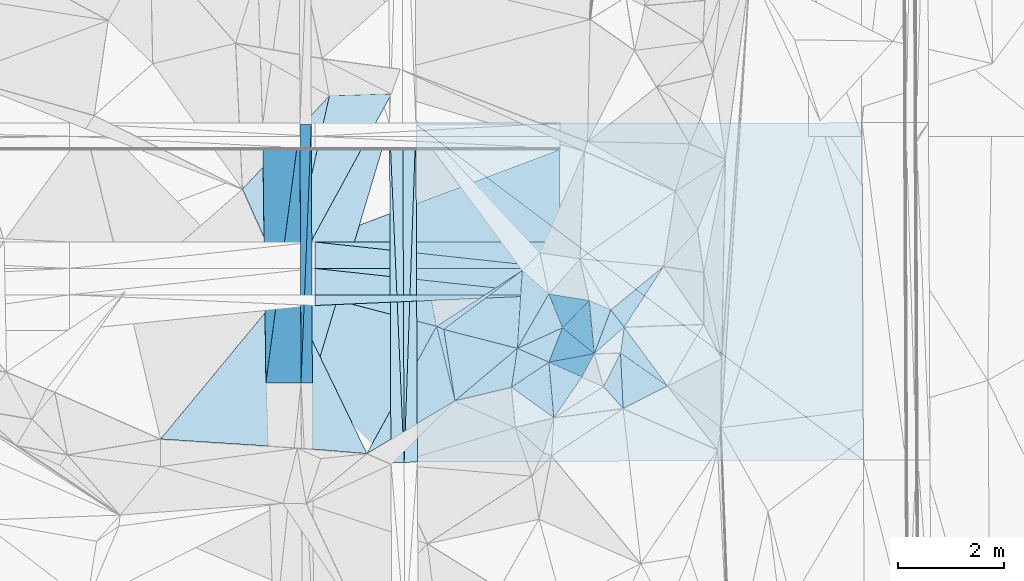
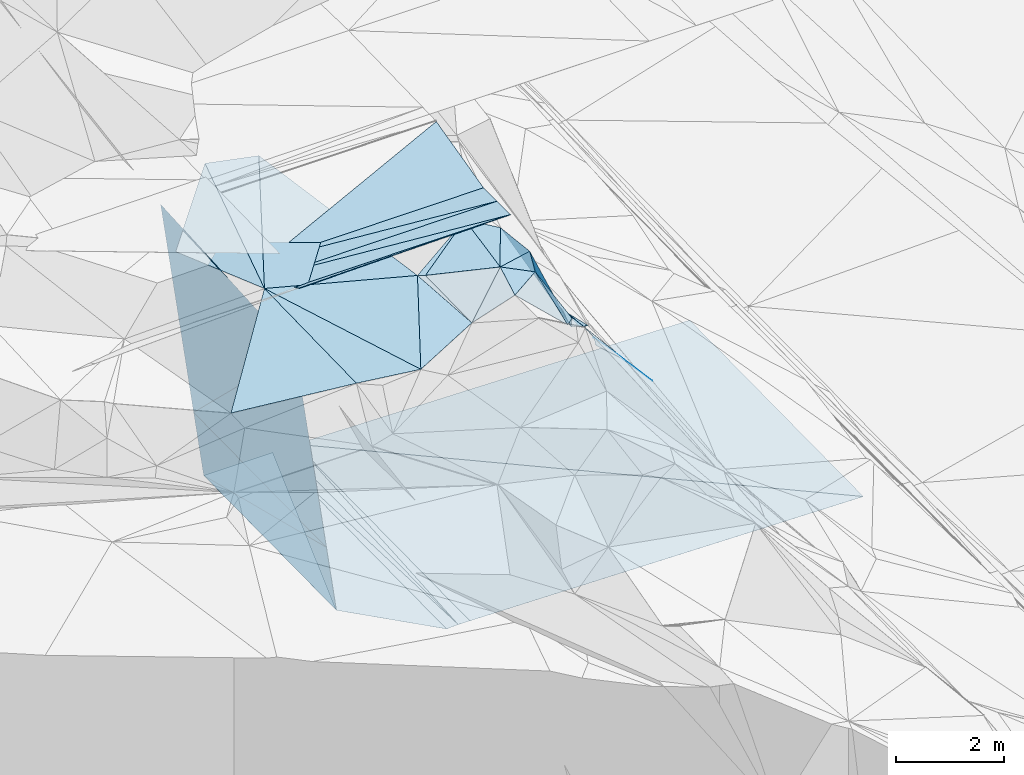
# One storey, part 59 of 275: 46 plates.
"""IFC2X3 building model written with IfcOpenShell, lengths in millimetres."""

import ifcopenshell
import ifcopenshell.guid

model = None  # the IFC model being written
_history = None  # IfcOwnerHistory: only IFC2X3 demands one
_inside = {}  # id of a spatial element -> (the spatial element, [elements in it])
_under = {}  # id of a project, library or spatial element -> (it, [spatial elements below it])
_declared = {}  # id of a project -> (the project, [libraries it declares])
_typed = {}  # id of a type object -> (the type object, [elements of that type])
_made_of = {}  # id of a material, layer set ... -> (it, [elements and type objects made of it])


def new_model(schema):
    """Start an empty IFC model of exactly this schema.

    Asked for "IFC4X3", IfcOpenShell would pick the latest addendum, in which some entities
    have other attributes; the version numbers below select the first issue.
    IFC2X3 requires an IfcOwnerHistory on every rooted entity: one is made here for all.
    """
    global model, _history
    if schema == "IFC4X3":
        model = ifcopenshell.file(schema_version=(4, 3, 0, 0))
    else:
        model = ifcopenshell.file(schema=schema)
    _inside.clear()
    _under.clear()
    _declared.clear()
    _typed.clear()
    _made_of.clear()
    _history = None
    if model.schema == "IFC2X3":
        org = make("IfcOrganization", Name="unknown")
        user = make(
            "IfcPersonAndOrganization",
            ThePerson=make("IfcPerson", FamilyName="unknown"),
            TheOrganization=org,
        )
        app = make(
            "IfcApplication",
            ApplicationDeveloper=org,
            Version="unknown",
            ApplicationFullName="unknown",
            ApplicationIdentifier="unknown",
        )
        _history = make(
            "IfcOwnerHistory",
            OwningUser=user,
            OwningApplication=app,
            ChangeAction="ADDED",
            CreationDate=0,
        )
    return model


def make(cls, **values):
    """One entity of the class cls with the attributes given. An attribute that is None is left unset."""
    return model.create_entity(
        cls, **{name: value for name, value in values.items() if value is not None}
    )


def rooted(cls, **values):
    """An entity with a GlobalId (a new one), such as an element, a storey or a relation."""
    return make(cls, GlobalId=ifcopenshell.guid.new(), OwnerHistory=_history, **values)


def si_unit(unit_type, name, prefix=None):
    """IfcSIUnit, for example si_unit("LENGTHUNIT", "METRE", prefix="MILLI")."""
    return make("IfcSIUnit", UnitType=unit_type, Prefix=prefix, Name=name)


def assignment(units):
    """IfcUnitAssignment: the units of a project."""
    return None if units is None else make("IfcUnitAssignment", Units=units)


def point(xyz):
    """IfcCartesianPoint."""
    return None if xyz is None else make("IfcCartesianPoint", Coordinates=xyz)


def direction(xyz):
    """IfcDirection."""
    return None if xyz is None else make("IfcDirection", DirectionRatios=xyz)


def frame(location, z_axis=None, x_axis=None):
    """IfcAxis2Placement3D, a coordinate frame: its origin and axes. An axis left out is left unset."""
    return make(
        "IfcAxis2Placement3D",
        Location=point(location),
        Axis=direction(z_axis),
        RefDirection=direction(x_axis),
    )


def origin_with_axes():
    """The frame at (0, 0, 0) with the z axis (0, 0, 1) and the x axis (1, 0, 0) written out."""
    return frame((0.0, 0.0, 0.0), z_axis=(0.0, 0.0, 1.0), x_axis=(1.0, 0.0, 0.0))


def place(relative_to, where):
    """IfcLocalPlacement: puts the frame where relative to a parent placement (None: the world)."""
    return make(
        "IfcLocalPlacement", PlacementRelTo=relative_to, RelativePlacement=where
    )


def context(
    kind, dimensions, precision=None, world=None, true_north=None, identifier=None
):
    """IfcGeometricRepresentationContext, for example the 3D "Model" context."""
    return make(
        "IfcGeometricRepresentationContext",
        ContextIdentifier=identifier,
        ContextType=kind,
        CoordinateSpaceDimension=dimensions,
        Precision=precision,
        WorldCoordinateSystem=world,
        TrueNorth=true_north,
    )


def subcontext(parent, identifier, kind, view, scale=None):
    """IfcGeometricRepresentationSubContext, for example "Body" below "Model"."""
    return make(
        "IfcGeometricRepresentationSubContext",
        ContextIdentifier=identifier,
        ContextType=kind,
        ParentContext=parent,
        TargetScale=scale,
        TargetView=view,
    )


def project(units=None, contexts=None):
    """IfcProject with its units and contexts."""
    return rooted(
        "IfcProject",
        Name="project",
        RepresentationContexts=contexts,
        UnitsInContext=assignment(units),
    )


def spatial(cls, under=None, at=None, **own):
    """A site, building, storey or space (cls), placed at a placement, below another one or the project."""
    s = rooted(cls, ObjectPlacement=at, **own)
    if under is not None:
        _under.setdefault(under.id(), (under, []))[1].append(s)
    return s


def polyline(points):
    """IfcPolyline through the points."""
    return make("IfcPolyline", Points=[point(p) for p in points])


def outline(outer, holes=None, kind="AREA"):
    """IfcArbitraryClosedProfileDef: a profile drawn as a closed curve; with holes, ...WithVoids."""
    if holes is None:
        return make("IfcArbitraryClosedProfileDef", ProfileType=kind, OuterCurve=outer)
    return make(
        "IfcArbitraryProfileDefWithVoids",
        ProfileType=kind,
        OuterCurve=outer,
        InnerCurves=holes,
    )


def extrude(swept, where, along, depth):
    """IfcExtrudedAreaSolid: the profile swept, set in the frame where, extruded along a direction by depth."""
    return make(
        "IfcExtrudedAreaSolid",
        SweptArea=swept,
        Position=where,
        ExtrudedDirection=direction(along),
        Depth=depth,
    )


def shape(context_of_items, identifier, shape_type, items):
    """IfcShapeRepresentation: the items that make up one representation, for example the "Body"."""
    return make(
        "IfcShapeRepresentation",
        ContextOfItems=context_of_items,
        RepresentationIdentifier=identifier,
        RepresentationType=shape_type,
        Items=items,
    )


def material(Name=None, Category=None):
    """IfcMaterial."""
    return make("IfcMaterial", Name=Name, Category=Category)


def made_of(thing, what):
    """Note that an element or type object is made of a material, layer set ...; save() writes the relation."""
    if what is not None:
        _made_of.setdefault(what.id(), (what, []))[1].append(thing)
    return thing


def type_object(cls, material=None, **own):
    """A type object (cls), such as IfcWallType, which elements share."""
    return made_of(rooted(cls, **own), material)


def element(
    cls,
    number,
    at=None,
    inside=None,
    cuts=None,
    type_object=None,
    material=None,
    context=None,
    identifier="Body",
    shape_type=None,
    held_by="IfcProductDefinitionShape",
    body=None,
    shapes=None,
    **own,
):
    """One element of the class cls, such as IfcWall. Its Tag is "e" and its number.

    at: its placement. inside: the storey or other place that contains it. cuts: it is an
    opening in that element (IfcRelVoidsElement). A single representation is given by context,
    identifier, shape_type and body (its items); several are given by shapes. held_by: the class
    of the entity that holds the representations. save() writes the other relations.
    """
    e = rooted(cls, Tag="e%d" % number, ObjectPlacement=at, **own)
    if body is not None:
        shapes = [shape(context, identifier, shape_type, body)]
    if shapes is not None:
        e.Representation = make(held_by, Representations=shapes)
    if inside is not None:
        _inside.setdefault(inside.id(), (inside, []))[1].append(e)
    if cuts is not None:
        rooted(
            "IfcRelVoidsElement", RelatingBuildingElement=cuts, RelatedOpeningElement=e
        )
    if type_object is not None:
        _typed.setdefault(type_object.id(), (type_object, []))[1].append(e)
    return made_of(e, material)


def aggregate(whole, parts):
    """IfcRelAggregates: a whole, such as a stair, and the parts it consists of."""
    return rooted("IfcRelAggregates", RelatingObject=whole, RelatedObjects=parts)


def save(model, path):
    """Write the relations noted so far, then the file.

    IfcRelAggregates (storeys below a building ...), IfcRelContainedInSpatialStructure (elements
    in a storey), IfcRelDefinesByType, IfcRelAssociatesMaterial and IfcRelDeclares: one each for
    every whole, place, type object, material and project.
    """
    for whole, parts in _under.values():
        aggregate(whole, parts)
    for where, things in _inside.values():
        rooted(
            "IfcRelContainedInSpatialStructure",
            RelatedElements=things,
            RelatingStructure=where,
        )
    for kind, things in _typed.values():
        rooted("IfcRelDefinesByType", RelatedObjects=things, RelatingType=kind)
    for what, things in _made_of.values():
        rooted("IfcRelAssociatesMaterial", RelatedObjects=things, RelatingMaterial=what)
    for by, libraries in _declared.values():
        rooted("IfcRelDeclares", RelatingContext=by, RelatedDefinitions=libraries)
    model.write(path)


model = new_model("IFC2X3")

# Units and contexts
model_context = context("Model", 3, precision=1e-05, world=origin_with_axes())
body_context = subcontext(model_context, "Body", "Model", "MODEL_VIEW")
ifc_project = project(units=[si_unit("LENGTHUNIT", "METRE", prefix="MILLI"), si_unit("AREAUNIT", "SQUARE_METRE"), si_unit("VOLUMEUNIT", "CUBIC_METRE"), si_unit("MASSUNIT", "GRAM", prefix="KILO"), si_unit("TIMEUNIT", "SECOND"), si_unit("PLANEANGLEUNIT", "RADIAN"), si_unit("SOLIDANGLEUNIT", "STERADIAN"), si_unit("THERMODYNAMICTEMPERATUREUNIT", "DEGREE_CELSIUS"), si_unit("LUMINOUSINTENSITYUNIT", "LUMEN")], contexts=[model_context])

# Site, building, storey
site_placement = place(None, origin_with_axes())
site = spatial("IfcSite", under=ifc_project, at=site_placement, CompositionType="ELEMENT")
building_placement = place(site_placement, origin_with_axes())
building = spatial("IfcBuilding", under=site, at=building_placement, Name="Undefined", CompositionType="ELEMENT")
storey_placement = place(building_placement, origin_with_axes())
storey = spatial("IfcBuildingStorey", under=building, at=storey_placement, Name="Undefined", CompositionType="ELEMENT", Elevation=0.0)

# Plates
ifc_material = material()
plate_type_1 = type_object("IfcPlateType", PredefinedType="NOTDEFINED")
plate_1_placement = place(storey_placement, frame((-105730.120090106, 55627.1401213638, 43859.1212907865), z_axis=(-0.989948726527029, -0.00130441056446912, -0.141420710508017), x_axis=(0.0381706499205315, 0.960384070101301, -0.276053327058928)))
element("IfcPlate", 1, at=plate_1_placement, inside=storey, type_object=plate_type_1, material=ifc_material, Name="00_PR", context=body_context, shape_type="SweptSolid", body=[
    extrude(outline(polyline([(0.0, 0.0), (5087.47705078125, 1.11322151497006e-08), (423.188995361328, 1454.93286132813), (0.0, 0.0)])), frame((-8.85201319254618e-08, 2.18876761149539e-07, -0.5000001331573), z_axis=(0.0, 0.0, 1.0), x_axis=(1.0, 0.0, 0.0)), (0.0, 0.0, 1.0), 1.0),
])
plate_2_placement = place(storey_placement, frame((-105535.927784358, 60513.072147531, 42454.7062909264), z_axis=(-0.989948726527029, -0.00130441056446912, -0.141420710508017), x_axis=(-0.038170649897134, -0.960384070108515, 0.276053327037065)))
element("IfcPlate", 2, at=plate_2_placement, inside=storey, type_object=plate_type_1, material=ifc_material, Name="00_PR", context=body_context, shape_type="SweptSolid", body=[
    extrude(outline(polyline([(0.0, 0.0), (5087.47705078125, 1.11322151497006e-08), (423.022155761719, 1454.98132324219), (0.0, 0.0)])), frame((-8.85201319254618e-08, 2.18876761149539e-07, -0.5000001331573), z_axis=(0.0, 0.0, 1.0), x_axis=(1.0, 0.0, 0.0)), (0.0, 0.0, 1.0), 1.0),
])
plate_type_2 = type_object("IfcPlateType", PredefinedType="NOTDEFINED")
plate_3_placement = place(storey_placement, frame((-104055.417053017, 60518.5701489042, 42454.277721949), z_axis=(0.0498544569168996, 0.019904250008953, -0.998558137494809), x_axis=(0.99874546627616, 0.00370463310154305, 0.0499376539937489)))
element("IfcPlate", 3, at=plate_3_placement, inside=storey, type_object=plate_type_2, material=ifc_material, Name="00_PR", context=body_context, shape_type="SweptSolid", body=[
    extrude(outline(polyline([(0.0, 0.0), (250.312118530273, 2.47382558882236e-10), (247.391189575195, 6396.5869140625), (0.0, 0.0)])), frame((-8.85201319254618e-08, 2.18876761149539e-07, -0.5000001331573), z_axis=(0.0, 0.0, 1.0), x_axis=(1.0, 0.0, 0.0)), (0.0, 0.0, 1.0), 1.0),
])
plate_4_placement = place(storey_placement, frame((-104055.417053017, 60518.5701489042, 42454.277721949), z_axis=(0.0498336597395354, 0.0199033673627597, -0.998559193200177), x_axis=(0.0432878790992274, -0.99890494977846, -0.0177499529910086)))
element("IfcPlate", 4, at=plate_4_placement, inside=storey, type_object=plate_type_2, material=ifc_material, Name="00_PR", context=body_context, shape_type="SweptSolid", body=[
    extrude(outline(polyline([(0.0, 0.0), (6401.369140625, -2.4156179279089e-09), (6391.95947265625, 250.135406494141), (0.0, 0.0)])), frame((-8.85201319254618e-08, 2.18876761149539e-07, -0.5000001331573), z_axis=(0.0, 0.0, 1.0), x_axis=(1.0, 0.0, 0.0)), (0.0, 0.0, 1.0), 1.0),
])
plate_5_placement = place(storey_placement, frame((-103778.350339783, 54124.2108116673, 42340.6531984239), z_axis=(-0.0200859532450271, 0.0196293112227441, -0.999605544514014), x_axis=(0.0348205058721632, 0.999214437497686, 0.0189219519867515)))
element("IfcPlate", 5, at=plate_5_placement, inside=storey, type_object=plate_type_2, material=ifc_material, Name="00_PR", context=body_context, shape_type="SweptSolid", body=[
    extrude(outline(polyline([(0.0, 0.0), (6401.2421875, -8.99308361113071e-09), (9.80232715606689, 249.858337402344), (0.0, 0.0)])), frame((-8.85201319254618e-08, 2.18876761149539e-07, -0.5000001331573), z_axis=(0.0, 0.0, 1.0), x_axis=(1.0, 0.0, 0.0)), (0.0, 0.0, 1.0), 1.0),
])
plate_6_placement = place(storey_placement, frame((-103555.455830217, 60520.4246375917, 42461.7771978521), z_axis=(-0.0200650799093575, 0.0196285920413662, -0.999605977844623), x_axis=(-0.0348205058711676, -0.999214437497641, -0.0189219519910026)))
element("IfcPlate", 6, at=plate_6_placement, inside=storey, type_object=plate_type_2, material=ifc_material, Name="00_PR", context=body_context, shape_type="SweptSolid", body=[
    extrude(outline(polyline([(0.0, 0.0), (6401.2421875, -8.99308361113071e-09), (9.53703498840332, 249.867874145508), (0.0, 0.0)])), frame((-8.85201319254618e-08, 2.18876761149539e-07, -0.5000001331573), z_axis=(0.0, 0.0, 1.0), x_axis=(1.0, 0.0, 0.0)), (0.0, 0.0, 1.0), 1.0),
])
plate_type_3 = type_object("IfcPlateType", PredefinedType="NOTDEFINED")
plate_7_placement = place(storey_placement, frame((-102815.242012465, 55288.6762094906, 48119.5153064191), z_axis=(0.0362101649150948, 0.242903602142612, -0.969374367323051), x_axis=(-0.234450651171216, 0.945003223802978, 0.228039029921135)))
element("IfcPlate", 7, at=plate_7_placement, inside=storey, type_object=plate_type_3, material=ifc_material, Name="00", context=body_context, shape_type="SweptSolid", body=[
    extrude(outline(polyline([(0.0, 0.0), (1490.97277832031, -1.23691279441118e-09), (1399.95849609375, 117.967704772949), (0.0, 0.0)])), frame((-8.85201319254618e-08, 2.18876761149539e-07, -0.5000001331573), z_axis=(0.0, 0.0, 1.0), x_axis=(1.0, 0.0, 0.0)), (0.0, 0.0, 1.0), 1.0),
])
plate_type_4 = type_object("IfcPlateType", PredefinedType="NOTDEFINED")
for number, where, z_axis, x_axis, name in (
    (8, (-100830.776224609, 57292.6692349808, 48658.0040002168), (0.00445954412724179, -2.55895633812821e-07, -0.999990056183616), (-0.999990054538875, 5.7357962472799e-05, -0.00445954408009802), "00_PR"),
    (9, (-105469.516442515, 57792.9344007716, 48637.3169995207), (0.00445976024364945, 1.74411737731609e-06, -0.999990055218314), (0.999990054538811, -5.7357974325105e-05, 0.00445954409423353), "00_PR"),
):
    element("IfcPlate", number, at=place(storey_placement, frame(where, z_axis=z_axis, x_axis=x_axis)), inside=storey, type_object=plate_type_4, material=ifc_material, Name=name, context=body_context, shape_type="SweptSolid", body=[
        extrude(outline(polyline([(0.0, 0.0), (4638.81494140625, -1.05137587524951e-08), (4638.81494140625, 500.0), (0.0, 0.0)])), frame((-8.85201319254618e-08, 2.18876761149539e-07, -0.5000001331573), z_axis=(0.0, 0.0, 1.0), x_axis=(1.0, 0.0, 0.0)), (0.0, 0.0, 1.0), 1.0),
    ])
plate_8_placement = place(storey_placement, frame((-105469.48779625, 58292.9344020778, 48637.3169995591), z_axis=(0.00445954401937214, -2.2587800795359e-06, -0.999990056181579), x_axis=(0.999990054538811, -5.7357974325105e-05, 0.00445954409423353)))
element("IfcPlate", 10, at=plate_8_placement, inside=storey, type_object=plate_type_4, material=ifc_material, Name="00_PR", context=body_context, shape_type="SweptSolid", body=[
    extrude(outline(polyline([(0.0, 0.0), (4638.8154296875, -1.62399373948574e-08), (4638.81494140625, 499.999084472656), (0.0, 0.0)])), frame((-8.85201319254618e-08, 2.18876761149539e-07, -0.5000001331573), z_axis=(0.0, 0.0, 1.0), x_axis=(1.0, 0.0, 0.0)), (0.0, 0.0, 1.0), 1.0),
])
plate_9_placement = place(storey_placement, frame((-100830.747578005, 57792.6692382015, 48658.0050004334), z_axis=(0.00445954412724179, -2.55895633812821e-07, -0.999990056183616), x_axis=(-0.999990054538875, 5.7357962472799e-05, -0.00445954408009802)))
element("IfcPlate", 11, at=plate_9_placement, inside=storey, type_object=plate_type_4, material=ifc_material, Name="00_PR", context=body_context, shape_type="SweptSolid", body=[
    extrude(outline(polyline([(0.0, 0.0), (4638.81494140625, -1.05137587524951e-08), (4638.81494140625, 500.0), (0.0, 0.0)])), frame((-8.85201319254618e-08, 2.18876761149539e-07, -0.5000001331573), z_axis=(0.0, 0.0, 1.0), x_axis=(1.0, 0.0, 0.0)), (0.0, 0.0, 1.0), 1.0),
])
plate_type_5 = type_object("IfcPlateType", PredefinedType="NOTDEFINED")
plate_10_placement = place(storey_placement, frame((-101039.40727555, 56019.2774843913, 48209.7373625198), z_axis=(-0.820169940615576, 0.226761577065617, -0.525262273228677), x_axis=(0.483445949940016, -0.216263713831913, -0.848239364546485)))
element("IfcPlate", 12, at=plate_10_placement, inside=storey, type_object=plate_type_5, material=ifc_material, Name="00", context=body_context, shape_type="SweptSolid", body=[
    extrude(outline(polyline([(0.0, 0.0), (1296.8037109375, 1.25874066725373e-09), (781.614013671875, 929.881469726563), (0.0, 0.0)])), frame((-8.85201319254618e-08, 2.18876761149539e-07, -0.5000001331573), z_axis=(0.0, 0.0, 1.0), x_axis=(1.0, 0.0, 0.0)), (0.0, 0.0, 1.0), 1.0),
])
plate_type_6 = type_object("IfcPlateType", PredefinedType="NOTDEFINED")
plate_11_placement = place(storey_placement, frame((-99683.5417203944, 56192.1026559963, 46139.6725936381), z_axis=(-0.747822800656728, -0.109527045952021, -0.654801408843132), x_axis=(0.627032317987849, -0.440615867730295, -0.642408070701999)))
element("IfcPlate", 13, at=plate_11_placement, inside=storey, type_object=plate_type_6, material=ifc_material, Name="00", context=body_context, shape_type="SweptSolid", body=[
    extrude(outline(polyline([(0.0, 0.0), (1416.54504394531, 3.70346242561936e-09), (416.082763671875, 972.663940429688), (0.0, 0.0)])), frame((-8.85201319254618e-08, 2.18876761149539e-07, -0.5000001331573), z_axis=(0.0, 0.0, 1.0), x_axis=(1.0, 0.0, 0.0)), (0.0, 0.0, 1.0), 1.0),
])
plate_type_7 = type_object("IfcPlateType", PredefinedType="NOTDEFINED")
plate_12_placement = place(storey_placement, frame((-106394.651324838, 55624.1377954479, 48510.8852904457), z_axis=(-0.989948726527029, -0.00130441056446912, -0.141420710508017), x_axis=(0.0959948649472527, 0.728131105993634, -0.678682605043217)))
element("IfcPlate", 14, at=plate_12_placement, inside=storey, type_object=plate_type_7, material=ifc_material, Name="00_PR", context=body_context, shape_type="SweptSolid", body=[
    extrude(outline(polyline([(0.0, 0.0), (6713.26904296875, -4.19095158576965e-09), (3223.04907226563, 3419.42602539063), (0.0, 0.0)])), frame((-8.85201319254618e-08, 2.18876761149539e-07, -0.5000001331573), z_axis=(0.0, 0.0, 1.0), x_axis=(1.0, 0.0, 0.0)), (0.0, 0.0, 1.0), 1.0),
])
plate_type_8 = type_object("IfcPlateType", PredefinedType="NOTDEFINED")
plate_13_placement = place(storey_placement, frame((-105750.211960232, 60512.2778903005, 43954.7062904961), z_axis=(-0.989948726527029, -0.00130441056446912, -0.141420710508017), x_axis=(-0.0959948649484216, -0.728131105996373, 0.678682605040112)))
element("IfcPlate", 15, at=plate_13_placement, inside=storey, type_object=plate_type_8, material=ifc_material, Name="00_PR", context=body_context, shape_type="SweptSolid", body=[
    extrude(outline(polyline([(0.0, 0.0), (6713.26904296875, -4.19095158576965e-09), (3434.6728515625, 3644.78002929688), (0.0, 0.0)])), frame((-8.85201319254618e-08, 2.18876761149539e-07, -0.5000001331573), z_axis=(0.0, 0.0, 1.0), x_axis=(1.0, 0.0, 0.0)), (0.0, 0.0, 1.0), 1.0),
])
plate_type_9 = type_object("IfcPlateType", PredefinedType="NOTDEFINED")
plate_14_placement = place(storey_placement, frame((-105515.341244283, 55628.1185405694, 42358.6920966973), z_axis=(-7.25346348639813e-05, 0.0195631431386758, -0.999808620771627), x_axis=(-0.0041121261103718, 0.999800164358326, 0.0195632760016451)))
element("IfcPlate", 16, at=plate_14_placement, inside=storey, type_object=plate_type_9, material=ifc_material, Name="00_PR", context=body_context, shape_type="SweptSolid", body=[
    extrude(outline(polyline([(0.0, 0.0), (4885.9404296875, -4.17639967054129e-09), (4885.3408203125, 1480.00085449219), (0.0, 0.0)])), frame((-8.85201319254618e-08, 2.18876761149539e-07, -0.5000001331573), z_axis=(0.0, 0.0, 1.0), x_axis=(1.0, 0.0, 0.0)), (0.0, 0.0, 1.0), 1.0),
])
plate_type_10 = type_object("IfcPlateType", PredefinedType="NOTDEFINED")
plate_15_placement = place(storey_placement, frame((-106008.294000302, 57441.3014991925, 48709.5060686009), z_axis=(0.141833520675663, 0.0635410110078352, -0.987849073660976), x_axis=(-0.408844089000753, 0.912604246587284, -7.30991896949323e-11)))
element("IfcPlate", 17, at=plate_15_placement, inside=storey, type_object=plate_type_10, material=ifc_material, Name="00", context=body_context, shape_type="SweptSolid", body=[
    extrude(outline(polyline([(0.0, 0.0), (2030.02465820313, -1.52795109897852e-09), (2969.07739257813, 2252.01684570313), (0.0, 0.0)])), frame((-8.85201319254618e-08, 2.18876761149539e-07, -0.5000001331573), z_axis=(0.0, 0.0, 1.0), x_axis=(1.0, 0.0, 0.0)), (0.0, 0.0, 1.0), 1.0),
])
plate_type_11 = type_object("IfcPlateType", PredefinedType="NOTDEFINED")
plate_16_placement = place(storey_placement, frame((-105515.341497288, 55628.1186161153, 42358.6920982971), z_axis=(-0.000579076287365106, 0.0197142950830962, -0.999805486702304), x_axis=(0.285996701790206, 0.958047624666376, 0.018725261980519)))
element("IfcPlate", 18, at=plate_16_placement, inside=storey, type_object=plate_type_11, material=ifc_material, Name="00_PR", context=body_context, shape_type="SweptSolid", body=[
    extrude(outline(polyline([(0.0, 0.0), (5104.6015625, -3.63797880709171e-09), (-1017.25048828125, 1855.43469238281), (0.0, 0.0)])), frame((-8.85201319254618e-08, 2.18876761149539e-07, -0.5000001331573), z_axis=(0.0, 0.0, 1.0), x_axis=(1.0, 0.0, 0.0)), (0.0, 0.0, 1.0), 1.0),
])
plate_type_12 = type_object("IfcPlateType", PredefinedType="NOTDEFINED")
plate_17_placement = place(storey_placement, frame((-103555.455830217, 60520.4246375917, 42461.7771978521), z_axis=(-0.0200678033418918, 0.0196576989667602, -0.999605351196343), x_axis=(0.999793062227796, 0.00372865612634485, -0.0199982460395676)))
element("IfcPlate", 19, at=plate_17_placement, inside=storey, type_object=plate_type_12, material=ifc_material, Name="00_PR", context=body_context, shape_type="SweptSolid", body=[
    extrude(outline(polyline([(0.0, 0.0), (8443.140625, -1.06010702438653e-08), (8449.048828125, 6387.3642578125), (0.0, 0.0)])), frame((-8.85201319254618e-08, 2.18876761149539e-07, -0.5000001331573), z_axis=(0.0, 0.0, 1.0), x_axis=(1.0, 0.0, 0.0)), (0.0, 0.0, 1.0), 1.0),
])
plate_type_13 = type_object("IfcPlateType", PredefinedType="NOTDEFINED")
plate_18_placement = place(storey_placement, frame((-95086.8597421477, 54165.8424125656, 42166.7981970274), z_axis=(-0.0200891201270537, 0.019629295827585, -0.999605481176366), x_axis=(-0.999788533200826, -0.00478946312305113, 0.0199987480391751)))
element("IfcPlate", 20, at=plate_18_placement, inside=storey, type_object=plate_type_13, material=ifc_material, Name="00_PR", context=body_context, shape_type="SweptSolid", body=[
    extrude(outline(polyline([(0.0, 0.0), (8443.2783203125, -4.42159944213927e-08), (8442.26953125, 6396.32177734375), (0.0, 0.0)])), frame((-8.85201319254618e-08, 2.18876761149539e-07, -0.5000001331573), z_axis=(0.0, 0.0, 1.0), x_axis=(1.0, 0.0, 0.0)), (0.0, 0.0, 1.0), 1.0),
])
plate_type_14 = type_object("IfcPlateType", PredefinedType="NOTDEFINED")
plate_19_placement = place(storey_placement, frame((-101635.486234979, 56280.3605210663, 48369.5098689028), z_axis=(0.0460585750559595, 0.192319486780277, -0.980250897815649), x_axis=(-0.145965367820168, -0.969464200270185, -0.197061604052168)))
element("IfcPlate", 21, at=plate_19_placement, inside=storey, type_object=plate_type_14, material=ifc_material, Name="00", context=body_context, shape_type="SweptSolid", body=[
    extrude(outline(polyline([(0.0, 0.0), (761.183288574219, 4.07453626394272e-10), (1182.89514160156, 1019.09722900391), (0.0, 0.0)])), frame((-8.85201319254618e-08, 2.18876761149539e-07, -0.5000001331573), z_axis=(0.0, 0.0, 1.0), x_axis=(1.0, 0.0, 0.0)), (0.0, 0.0, 1.0), 1.0),
])
plate_type_15 = type_object("IfcPlateType", PredefinedType="NOTDEFINED")
plate_20_placement = place(storey_placement, frame((-103164.915560801, 56697.6213989266, 48459.5180721526), z_axis=(-0.191782723002895, 0.185004821360146, -0.963842623684539), x_axis=(0.234450651155877, -0.94500322380871, -0.228039029913151)))
element("IfcPlate", 22, at=plate_20_placement, inside=storey, type_object=plate_type_15, material=ifc_material, Name="00", context=body_context, shape_type="SweptSolid", body=[
    extrude(outline(polyline([(0.0, 0.0), (1490.97277832031, -1.23691279441118e-09), (2012.84692382813, 1878.76220703125), (0.0, 0.0)])), frame((-8.85201319254618e-08, 2.18876761149539e-07, -0.5000001331573), z_axis=(0.0, 0.0, 1.0), x_axis=(1.0, 0.0, 0.0)), (0.0, 0.0, 1.0), 1.0),
])
plate_type_16 = type_object("IfcPlateType", PredefinedType="NOTDEFINED")
plate_21_placement = place(storey_placement, frame((-100276.620489238, 57187.424470591, 46999.7281634048), z_axis=(-0.825084440290661, 0.153842291560139, -0.543661857883898), x_axis=(0.506691120150342, -0.224284012893434, -0.832442664885222)))
element("IfcPlate", 23, at=plate_21_placement, inside=storey, type_object=plate_type_16, material=ifc_material, Name="00", context=body_context, shape_type="SweptSolid", body=[
    extrude(outline(polyline([(0.0, 0.0), (804.860229492188, 9.64064383879304e-10), (632.28369140625, 899.509521484375), (0.0, 0.0)])), frame((-8.85201319254618e-08, 2.18876761149539e-07, -0.5000001331573), z_axis=(0.0, 0.0, 1.0), x_axis=(1.0, 0.0, 0.0)), (0.0, 0.0, 1.0), 1.0),
])
plate_type_17 = type_object("IfcPlateType", PredefinedType="NOTDEFINED")
plate_22_placement = place(storey_placement, frame((-100830.618319398, 60042.7896071571, 49095.5199287508), z_axis=(0.00434030611226815, 0.242533626751396, -0.970133290655293), x_axis=(-5.55829338407661e-05, -0.970142368584362, -0.242536144910531)))
element("IfcPlate", 24, at=plate_22_placement, inside=storey, type_object=plate_type_17, material=ifc_material, Name="00_PR", context=body_context, shape_type="SweptSolid", body=[
    extrude(outline(polyline([(0.0, 0.0), (1803.85900878906, -5.93718141317368e-09), (1808.8759765625, 4638.8125), (0.0, 0.0)])), frame((-8.85201319254618e-08, 2.18876761149539e-07, -0.5000001331573), z_axis=(0.0, 0.0, 1.0), x_axis=(1.0, 0.0, 0.0)), (0.0, 0.0, 1.0), 1.0),
])
plate_type_18 = type_object("IfcPlateType", PredefinedType="NOTDEFINED")
plate_23_placement = place(storey_placement, frame((-105469.545336165, 57292.7107902354, 48637.3697848627), z_axis=(0.0039631801926412, -0.447211163353112, -0.894419626671462), x_axis=(0.999990054538811, -5.7357974325105e-05, 0.00445954409423353)))
element("IfcPlate", 25, at=plate_23_placement, inside=storey, type_object=plate_type_18, material=ifc_material, Name="00_PR", context=body_context, shape_type="SweptSolid", body=[
    extrude(outline(polyline([(0.0, 0.0), (4638.81494140625, -1.05137587524951e-08), (0.449469774961472, 225.455123901367), (0.0, 0.0)])), frame((-8.85201319254618e-08, 2.18876761149539e-07, -0.5000001331573), z_axis=(0.0, 0.0, 1.0), x_axis=(1.0, 0.0, 0.0)), (0.0, 0.0, 1.0), 1.0),
])
plate_type_19 = type_object("IfcPlateType", PredefinedType="NOTDEFINED")
plate_24_placement = place(storey_placement, frame((-100181.150068866, 56179.8769503379, 46569.7652710262), z_axis=(-0.875367185638906, -0.115552981324531, -0.469446268292373), x_axis=(-0.314886168992913, -0.600538614108327, 0.734983043030121)))
element("IfcPlate", 26, at=plate_24_placement, inside=storey, type_object=plate_type_19, material=ifc_material, Name="00", context=body_context, shape_type="SweptSolid", body=[
    extrude(outline(polyline([(0.0, 0.0), (734.710815429688, -1.30967237055302e-09), (1572.18322753906, 990.121215820313), (0.0, 0.0)])), frame((-8.85201319254618e-08, 2.18876761149539e-07, -0.5000001331573), z_axis=(0.0, 0.0, 1.0), x_axis=(1.0, 0.0, 0.0)), (0.0, 0.0, 1.0), 1.0),
])
plate_type_20 = type_object("IfcPlateType", PredefinedType="NOTDEFINED")
plate_25_placement = place(storey_placement, frame((-103028.896735603, 56637.4039519576, 48449.5024970815), z_axis=(-0.031156443732163, 0.0949698115710919, -0.994992467762503), x_axis=(-0.91235955133777, 0.403850893931803, 0.0671156058843822)))
element("IfcPlate", 27, at=plate_25_placement, inside=storey, type_object=plate_type_20, material=ifc_material, Name="00", context=body_context, shape_type="SweptSolid", body=[
    extrude(outline(polyline([(0.0, 0.0), (148.996643066406, -4.40195435658097e-10), (-900.69140625, 1626.30102539063), (0.0, 0.0)])), frame((-8.85201319254618e-08, 2.18876761149539e-07, -0.5000001331573), z_axis=(0.0, 0.0, 1.0), x_axis=(1.0, 0.0, 0.0)), (0.0, 0.0, 1.0), 1.0),
])
plate_type_21 = type_object("IfcPlateType", PredefinedType="NOTDEFINED")
plate_26_placement = place(storey_placement, frame((-101635.590158577, 56280.37431202, 48369.5189875029), z_axis=(-0.161781649552401, 0.219905260772818, -0.962012668395039), x_axis=(0.889623177210243, -0.389398382899536, -0.238619994898958)))
element("IfcPlate", 28, at=plate_26_placement, inside=storey, type_object=plate_type_21, material=ifc_material, Name="00", context=body_context, shape_type="SweptSolid", body=[
    extrude(outline(polyline([(0.0, 0.0), (670.522155761719, -3.72892827726901e-10), (224.302795410156, 727.384521484375), (0.0, 0.0)])), frame((-8.85201319254618e-08, 2.18876761149539e-07, -0.5000001331573), z_axis=(0.0, 0.0, 1.0), x_axis=(1.0, 0.0, 0.0)), (0.0, 0.0, 1.0), 1.0),
])
plate_type_22 = type_object("IfcPlateType", PredefinedType="NOTDEFINED")
plate_27_placement = place(storey_placement, frame((-106008.474066721, 57441.3410292626, 48709.5172899797), z_axis=(-0.218301917734424, 0.142603437870221, -0.965405889883145), x_axis=(0.219061342806923, 0.971180172978661, 0.0939212420103415)))
element("IfcPlate", 29, at=plate_27_placement, inside=storey, type_object=plate_type_22, material=ifc_material, Name="00", context=body_context, shape_type="SweptSolid", body=[
    extrude(outline(polyline([(0.0, 0.0), (3726.52661132813, -1.61526259034872e-08), (3996.6708984375, 1173.16748046875), (0.0, 0.0)])), frame((-8.85201319254618e-08, 2.18876761149539e-07, -0.5000001331573), z_axis=(0.0, 0.0, 1.0), x_axis=(1.0, 0.0, 0.0)), (0.0, 0.0, 1.0), 1.0),
])
plate_type_23 = type_object("IfcPlateType", PredefinedType="NOTDEFINED")
plate_28_placement = place(storey_placement, frame((-101040.675968517, 57308.7725067528, 48429.5363698174), z_axis=(-0.298116489265785, 0.226575396245067, -0.92724869837829), x_axis=(0.35672863114981, -0.874585450730942, -0.328397583864038)))
element("IfcPlate", 30, at=plate_28_placement, inside=storey, type_object=plate_type_23, material=ifc_material, Name="00", context=body_context, shape_type="SweptSolid", body=[
    extrude(outline(polyline([(0.0, 0.0), (730.821472167969, -1.36788003146648e-09), (706.875793457031, 956.83154296875), (0.0, 0.0)])), frame((-8.85201319254618e-08, 2.18876761149539e-07, -0.5000001331573), z_axis=(0.0, 0.0, 1.0), x_axis=(1.0, 0.0, 0.0)), (0.0, 0.0, 1.0), 1.0),
])
plate_type_24 = type_object("IfcPlateType", PredefinedType="NOTDEFINED")
plate_29_placement = place(storey_placement, frame((-102815.257441315, 55288.6739818841, 48119.5144234651), z_axis=(0.00535161842377398, 0.238448364201782, -0.97114043154929), x_axis=(-0.15205211117878, 0.960055931770173, 0.234888831916252)))
element("IfcPlate", 31, at=plate_29_placement, inside=storey, type_object=plate_type_24, material=ifc_material, Name="00", context=body_context, shape_type="SweptSolid", body=[
    extrude(outline(polyline([(0.0, 0.0), (1404.919921875, 2.03726813197136e-09), (831.435302734375, 1321.55798339844), (0.0, 0.0)])), frame((-8.85201319254618e-08, 2.18876761149539e-07, -0.5000001331573), z_axis=(0.0, 0.0, 1.0), x_axis=(1.0, 0.0, 0.0)), (0.0, 0.0, 1.0), 1.0),
])
plate_type_25 = type_object("IfcPlateType", PredefinedType="NOTDEFINED")
plate_30_placement = place(storey_placement, frame((-101039.113576296, 56019.1955636763, 48209.5147466947), z_axis=(-0.232770951050884, 0.0629197850214851, -0.970494093232781), x_axis=(-0.889623177219329, 0.389398382878764, 0.238619994898982)))
element("IfcPlate", 32, at=plate_30_placement, inside=storey, type_object=plate_type_25, material=ifc_material, Name="00", context=body_context, shape_type="SweptSolid", body=[
    extrude(outline(polyline([(0.0, 0.0), (670.522155761719, -3.72892827726901e-10), (17.8964996337891, 700.128356933594), (0.0, 0.0)])), frame((-8.85201319254618e-08, 2.18876761149539e-07, -0.5000001331573), z_axis=(0.0, 0.0, 1.0), x_axis=(1.0, 0.0, 0.0)), (0.0, 0.0, 1.0), 1.0),
])
plate_type_26 = type_object("IfcPlateType", PredefinedType="NOTDEFINED")
plate_31_placement = place(storey_placement, frame((-100181.176890092, 56179.9683578639, 46569.8180476002), z_axis=(-0.929009467022956, 0.0672588606521297, -0.363892368490327), x_axis=(-0.333715298291612, 0.272693386058388, 0.902370443269366)))
element("IfcPlate", 33, at=plate_31_placement, inside=storey, type_object=plate_type_26, material=ifc_material, Name="00", context=body_context, shape_type="SweptSolid", body=[
    extrude(outline(polyline([(0.0, 0.0), (1795.27160644531, 1.2832970242016e-09), (694.602416992188, 852.30712890625), (0.0, 0.0)])), frame((-8.85201319254618e-08, 2.18876761149539e-07, -0.5000001331573), z_axis=(0.0, 0.0, 1.0), x_axis=(1.0, 0.0, 0.0)), (0.0, 0.0, 1.0), 1.0),
])
plate_type_27 = type_object("IfcPlateType", PredefinedType="NOTDEFINED")
plate_32_placement = place(storey_placement, frame((-99868.7349419398, 57006.8541477153, 46329.6365345302), z_axis=(-0.68505944664246, 0.0477654766476515, -0.726919537367479), x_axis=(0.519442305250312, -0.667583632935161, -0.53339646094939)))
element("IfcPlate", 34, at=plate_32_placement, inside=storey, type_object=plate_type_27, material=ifc_material, Name="00", context=body_context, shape_type="SweptSolid", body=[
    extrude(outline(polyline([(0.0, 0.0), (487.442291259766, -8.14907252788544e-10), (261.774566650391, 877.709533691406), (0.0, 0.0)])), frame((-8.85201319254618e-08, 2.18876761149539e-07, -0.5000001331573), z_axis=(0.0, 0.0, 1.0), x_axis=(1.0, 0.0, 0.0)), (0.0, 0.0, 1.0), 1.0),
])
plate_type_28 = type_object("IfcPlateType", PredefinedType="NOTDEFINED")
plate_33_placement = place(storey_placement, frame((-101543.301808425, 57753.4027578244, 48509.5036919662), z_axis=(-0.0705972503626031, 0.0987562059976472, -0.992604271609885), x_axis=(0.74375948026014, -0.657886307943132, -0.118353036902827)))
element("IfcPlate", 35, at=plate_33_placement, inside=storey, type_object=plate_type_28, material=ifc_material, Name="00", context=body_context, shape_type="SweptSolid", body=[
    extrude(outline(polyline([(0.0, 0.0), (675.943786621094, -1.98997440747917e-09), (917.088073730469, 1164.92468261719), (0.0, 0.0)])), frame((-8.85201319254618e-08, 2.18876761149539e-07, -0.5000001331573), z_axis=(0.0, 0.0, 1.0), x_axis=(1.0, 0.0, 0.0)), (0.0, 0.0, 1.0), 1.0),
])
plate_type_29 = type_object("IfcPlateType", PredefinedType="NOTDEFINED")
plate_34_placement = place(storey_placement, frame((-99615.5674832106, 56681.396427294, 46069.6682397128), z_axis=(-0.746450465656614, -0.0506669869901355, -0.663509275557143), x_axis=(-0.519442305248487, 0.667583632936096, 0.533396460949998)))
element("IfcPlate", 36, at=plate_34_placement, inside=storey, type_object=plate_type_29, material=ifc_material, Name="00", context=body_context, shape_type="SweptSolid", body=[
    extrude(outline(polyline([(0.0, 0.0), (487.442291259766, -8.14907252788544e-10), (-116.526611328125, 1654.18310546875), (0.0, 0.0)])), frame((-8.85201319254618e-08, 2.18876761149539e-07, -0.5000001331573), z_axis=(0.0, 0.0, 1.0), x_axis=(1.0, 0.0, 0.0)), (0.0, 0.0, 1.0), 1.0),
])
plate_type_30 = type_object("IfcPlateType", PredefinedType="NOTDEFINED")
plate_35_placement = place(storey_placement, frame((-100780.247124992, 56669.6564928329, 48189.7934801678), z_axis=(-0.85030633494871, 0.326169774085033, -0.41302834675045), x_axis=(0.333715298308091, -0.27269338603995, -0.902370443268844)))
element("IfcPlate", 37, at=plate_35_placement, inside=storey, type_object=plate_type_30, material=ifc_material, Name="00", context=body_context, shape_type="SweptSolid", body=[
    extrude(outline(polyline([(0.0, 0.0), (1795.27160644531, 1.2832970242016e-09), (72.8023529052734, 696.562866210938), (0.0, 0.0)])), frame((-8.85201319254618e-08, 2.18876761149539e-07, -0.5000001331573), z_axis=(0.0, 0.0, 1.0), x_axis=(1.0, 0.0, 0.0)), (0.0, 0.0, 1.0), 1.0),
])
plate_type_31 = type_object("IfcPlateType", PredefinedType="NOTDEFINED")
plate_36_placement = place(storey_placement, frame((-100780.258424989, 56669.4000046632, 48189.7746389775), z_axis=(-0.872905141579252, -0.186806193296036, -0.450710616638603), x_axis=(-0.356728631158968, 0.874585450728432, 0.328397583860773)))
element("IfcPlate", 38, at=plate_36_placement, inside=storey, type_object=plate_type_31, material=ifc_material, Name="00", context=body_context, shape_type="SweptSolid", body=[
    extrude(outline(polyline([(0.0, 0.0), (730.821472167969, -1.36788003146648e-09), (-117.538970947266, 1387.11376953125), (0.0, 0.0)])), frame((-8.85201319254618e-08, 2.18876761149539e-07, -0.5000001331573), z_axis=(0.0, 0.0, 1.0), x_axis=(1.0, 0.0, 0.0)), (0.0, 0.0, 1.0), 1.0),
])
plate_type_32 = type_object("IfcPlateType", PredefinedType="NOTDEFINED")
plate_37_placement = place(storey_placement, frame((-98795.3061449934, 55568.004941102, 45229.6508310844), z_axis=(-0.715779163298816, -0.00046765476330568, -0.698326550179977), x_axis=(-0.627032317986931, 0.440615867732503, 0.64240807070138)))
element("IfcPlate", 39, at=plate_37_placement, inside=storey, type_object=plate_type_32, material=ifc_material, Name="00", context=body_context, shape_type="SweptSolid", body=[
    extrude(outline(polyline([(0.0, 0.0), (1416.54504394531, 3.70346242561936e-09), (1544.53259277344, 482.202453613281), (0.0, 0.0)])), frame((-8.85201319254618e-08, 2.18876761149539e-07, -0.5000001331573), z_axis=(0.0, 0.0, 1.0), x_axis=(1.0, 0.0, 0.0)), (0.0, 0.0, 1.0), 1.0),
])
plate_type_33 = type_object("IfcPlateType", PredefinedType="NOTDEFINED")
plate_38_placement = place(storey_placement, frame((-99634.7481997908, 55142.1322104813, 46259.5945025204), z_axis=(-0.572786496816556, -0.119257330762092, -0.810982933312483), x_axis=(-0.625229940445583, 0.70337505218802, 0.338158332042717)))
element("IfcPlate", 40, at=plate_38_placement, inside=storey, type_object=plate_type_33, material=ifc_material, Name="00", context=body_context, shape_type="SweptSolid", body=[
    extrude(outline(polyline([(0.0, 0.0), (591.438903808594, 3.92901711165905e-10), (728.39306640625, 767.231079101563), (0.0, 0.0)])), frame((-8.85201319254618e-08, 2.18876761149539e-07, -0.5000001331573), z_axis=(0.0, 0.0, 1.0), x_axis=(1.0, 0.0, 0.0)), (0.0, 0.0, 1.0), 1.0),
])
plate_type_34 = type_object("IfcPlateType", PredefinedType="NOTDEFINED")
plate_39_placement = place(storey_placement, frame((-104017.22952353, 61098.7373547739, 48799.5022558783), z_axis=(-0.0710030931183841, 0.0631513550945504, -0.995474995726836), x_axis=(0.189592152240754, -0.978946159204889, -0.0756256119758104)))
element("IfcPlate", 41, at=plate_39_placement, inside=storey, type_object=plate_type_34, material=ifc_material, Name="00", context=body_context, shape_type="SweptSolid", body=[
    extrude(outline(polyline([(0.0, 0.0), (4495.83154296875, -7.79982656240463e-09), (3209.72900390625, 2654.6826171875), (0.0, 0.0)])), frame((-8.85201319254618e-08, 2.18876761149539e-07, -0.5000001331573), z_axis=(0.0, 0.0, 1.0), x_axis=(1.0, 0.0, 0.0)), (0.0, 0.0, 1.0), 1.0),
])
plate_type_35 = type_object("IfcPlateType", PredefinedType="NOTDEFINED")
plate_40_placement = place(storey_placement, frame((-101635.525450165, 56280.3126434133, 48369.5025939996), z_axis=(-0.0323669933406873, 0.096570930638122, -0.994799694962645), x_axis=(-0.967199668033331, 0.247873070808895, 0.0555314588677757)))
element("IfcPlate", 42, at=plate_40_placement, inside=storey, type_object=plate_type_35, material=ifc_material, Name="00", context=body_context, shape_type="SweptSolid", body=[
    extrude(outline(polyline([(0.0, 0.0), (1440.62487792969, -4.57657733932137e-09), (283.696350097656, 1455.20324707031), (0.0, 0.0)])), frame((-8.85201319254618e-08, 2.18876761149539e-07, -0.5000001331573), z_axis=(0.0, 0.0, 1.0), x_axis=(1.0, 0.0, 0.0)), (0.0, 0.0, 1.0), 1.0),
])
plate_type_36 = type_object("IfcPlateType", PredefinedType="NOTDEFINED")
plate_41_placement = place(storey_placement, frame((-104483.438192762, 54288.7227966723, 48259.5040719458), z_axis=(-0.0574387796264945, 0.113790936521512, -0.991842935832371), x_axis=(-0.43189474202045, 0.892873966626013, 0.127448073883515)))
element("IfcPlate", 43, at=plate_41_placement, inside=storey, type_object=plate_type_36, material=ifc_material, Name="00", context=body_context, shape_type="SweptSolid", body=[
    extrude(outline(polyline([(0.0, 0.0), (3530.84985351563, -2.51748133450747e-09), (1606.80871582031, 2235.94848632813), (0.0, 0.0)])), frame((-8.85201319254618e-08, 2.18876761149539e-07, -0.5000001331573), z_axis=(0.0, 0.0, 1.0), x_axis=(1.0, 0.0, 0.0)), (0.0, 0.0, 1.0), 1.0),
])
plate_type_37 = type_object("IfcPlateType", PredefinedType="NOTDEFINED")
plate_42_placement = place(storey_placement, frame((-100945.777241739, 54967.3046528267, 47609.5818189601), z_axis=(-0.314425789066111, 0.449060769452093, -0.836349716631295), x_axis=(-0.690770204894096, 0.496084617704863, 0.526057578699507)))
element("IfcPlate", 44, at=plate_42_placement, inside=storey, type_object=plate_type_37, material=ifc_material, Name="00", context=body_context, shape_type="SweptSolid", body=[
    extrude(outline(polyline([(0.0, 0.0), (1159.56884765625, -2.11002770811319e-10), (902.059387207031, 813.565551757813), (0.0, 0.0)])), frame((-8.85201319254618e-08, 2.18876761149539e-07, -0.5000001331573), z_axis=(0.0, 0.0, 1.0), x_axis=(1.0, 0.0, 0.0)), (0.0, 0.0, 1.0), 1.0),
])
plate_type_38 = type_object("IfcPlateType", PredefinedType="NOTDEFINED")
plate_43_placement = place(storey_placement, frame((-104483.434859886, 54288.7244058488, 48259.5040773491), z_axis=(-0.0507776102230254, 0.117011415452522, -0.991831620263155), x_axis=(-0.994873901987158, 0.0810337958256666, 0.0604933308632538)))
element("IfcPlate", 45, at=plate_43_placement, inside=storey, type_object=plate_type_38, material=ifc_material, Name="00", context=body_context, shape_type="SweptSolid", body=[
    extrude(outline(polyline([(0.0, 0.0), (1322.45983886719, -8.57835402712226e-09), (1799.82788085938, 3037.68334960938), (0.0, 0.0)])), frame((-8.85201319254618e-08, 2.18876761149539e-07, -0.5000001331573), z_axis=(0.0, 0.0, 1.0), x_axis=(1.0, 0.0, 0.0)), (0.0, 0.0, 1.0), 1.0),
])
plate_type_39 = type_object("IfcPlateType", PredefinedType="NOTDEFINED")
plate_44_placement = place(storey_placement, frame((-106008.386018567, 57441.3285518433, 48709.5039123822), z_axis=(-0.0422091621181669, 0.117639975369098, -0.992158869752441), x_axis=(0.0680576142182522, -0.990398738928162, -0.120326634941838)))
element("IfcPlate", 46, at=plate_44_placement, inside=storey, type_object=plate_type_39, material=ifc_material, Name="00", context=body_context, shape_type="SweptSolid", body=[
    extrude(outline(polyline([(0.0, 0.0), (3074.96337890625, 5.1368260756135e-09), (2717.203125, 2572.72387695313), (0.0, 0.0)])), frame((-8.85201319254618e-08, 2.18876761149539e-07, -0.5000001331573), z_axis=(0.0, 0.0, 1.0), x_axis=(1.0, 0.0, 0.0)), (0.0, 0.0, 1.0), 1.0),
])

save(model, "model.ifc")
